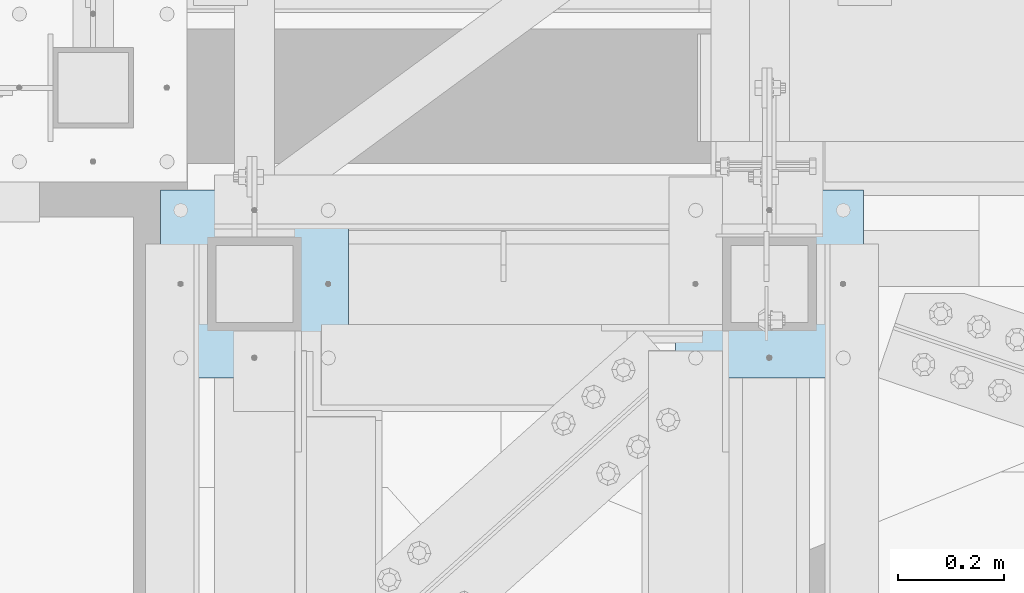
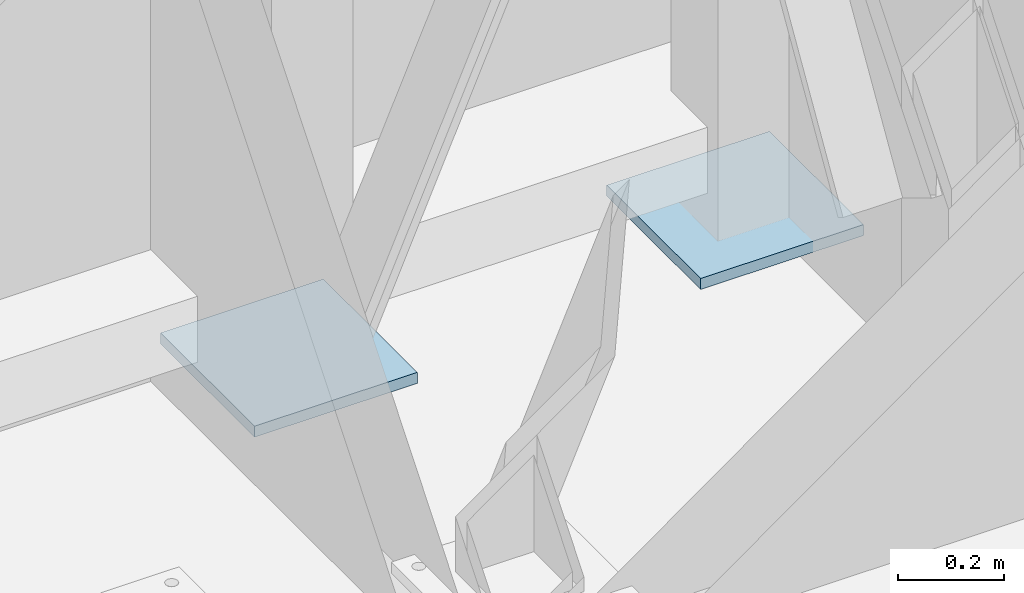
# One storey, part 1451 of 1763: 2 plates, 1 element without a shape of its own.
"""IFC2X3 building model written with IfcOpenShell, lengths in millimetres."""

from ifc_helpers import new_model, si_unit, frame, origin_with_axes, place, context, subcontext, project, spatial, faceted_brep, material, type_object, element, aggregate, save


model = new_model("IFC2X3")

# Units and contexts
model_context = context("Model", 3, precision=1e-05, world=origin_with_axes())
body_context = subcontext(model_context, "Body", "Model", "MODEL_VIEW")
ifc_project = project(units=[si_unit("LENGTHUNIT", "METRE", prefix="MILLI"), si_unit("AREAUNIT", "SQUARE_METRE"), si_unit("VOLUMEUNIT", "CUBIC_METRE"), si_unit("MASSUNIT", "GRAM", prefix="KILO"), si_unit("TIMEUNIT", "SECOND"), si_unit("PLANEANGLEUNIT", "RADIAN"), si_unit("SOLIDANGLEUNIT", "STERADIAN"), si_unit("THERMODYNAMICTEMPERATUREUNIT", "DEGREE_CELSIUS"), si_unit("LUMINOUSINTENSITYUNIT", "LUMEN")], contexts=[model_context])

# Site, building, storey
site_placement = place(None, origin_with_axes())
site = spatial("IfcSite", under=ifc_project, at=site_placement, CompositionType="ELEMENT")
building_placement = place(site_placement, origin_with_axes())
building = spatial("IfcBuilding", under=site, at=building_placement, Name="Undefined", CompositionType="ELEMENT")
storey_placement = place(building_placement, origin_with_axes())
storey = spatial("IfcBuildingStorey", under=building, at=storey_placement, Name="Undefined", CompositionType="ELEMENT", Elevation=0.0)

# Assembly, plates
assembly_placement = place(storey_placement, origin_with_axes())
assembly = element("IfcElementAssembly", 1, at=assembly_placement, inside=storey, Name="FRAME", AssemblyPlace="NOTDEFINED", PredefinedType="RIGID_FRAME")
ifc_material = material(Name="STEEL/A36")
plate_type = type_object("IfcPlateType", PredefinedType="NOTDEFINED")
plate_1_placement = place(assembly_placement, frame((-63388.3025957005, -14401.8023151462, 5079.99999999999), z_axis=(1.0, 0.0, 0.0), x_axis=(0.0, -1.0, 0.0)))
plate_1 = element("IfcPlate", 2, at=plate_1_placement, type_object=plate_type, material=ifc_material, Name="PLATE", context=body_context, shape_type="Brep", body=[
    faceted_brep([(0.0, -12.6999999999971, -1.81898940354586e-12), (0.0, -12.6999999999998, 355.600006103516), (0.0, 12.6999999999998, 355.600006103516), (0.0, 12.6999999999971, -1.81898940354586e-12), (355.600006103516, -12.6999999999998, 355.600006103516), (355.600006103516, 12.6999999999998, 355.600006103516), (355.600006103516, -12.6999999999998, 0.0), (355.600006103516, 12.6999999999998, 0.0)], [[[0, 1, 2, 3]], [[1, 4, 5, 2]], [[4, 6, 7, 5]], [[6, 0, 3, 7]], [[5, 7, 3, 2]], [[6, 4, 1, 0]]]),
])
plate_2_placement = place(assembly_placement, frame((-64363.0277910131, -14401.8023151462, 5080.0), z_axis=(1.0, 0.0, 0.0), x_axis=(0.0, -1.0, 0.0)))
plate_2 = element("IfcPlate", 3, at=plate_2_placement, type_object=plate_type, material=ifc_material, Name="PLATE", context=body_context, shape_type="Brep", body=[
    faceted_brep([(0.0, -12.6999999999971, -1.81898940354586e-12), (0.0, -12.6999999999998, 355.600006103516), (0.0, 12.6999999999998, 355.600006103516), (0.0, 12.6999999999971, -1.81898940354586e-12), (355.600006103516, -12.6999999999998, 355.600006103516), (355.600006103516, 12.6999999999998, 355.600006103516), (355.600006103516, -12.6999999999998, 0.0), (355.600006103516, 12.6999999999998, 0.0)], [[[0, 1, 2, 3]], [[1, 4, 5, 2]], [[4, 6, 7, 5]], [[6, 0, 3, 7]], [[5, 7, 3, 2]], [[6, 4, 1, 0]]]),
])
aggregate(assembly, [plate_1, plate_2])

save(model, "model.ifc")
